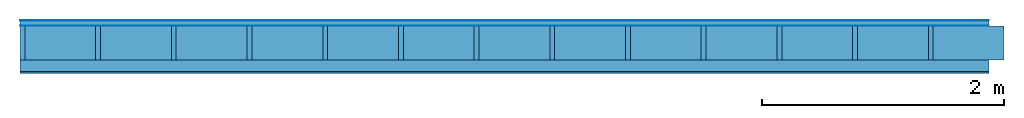
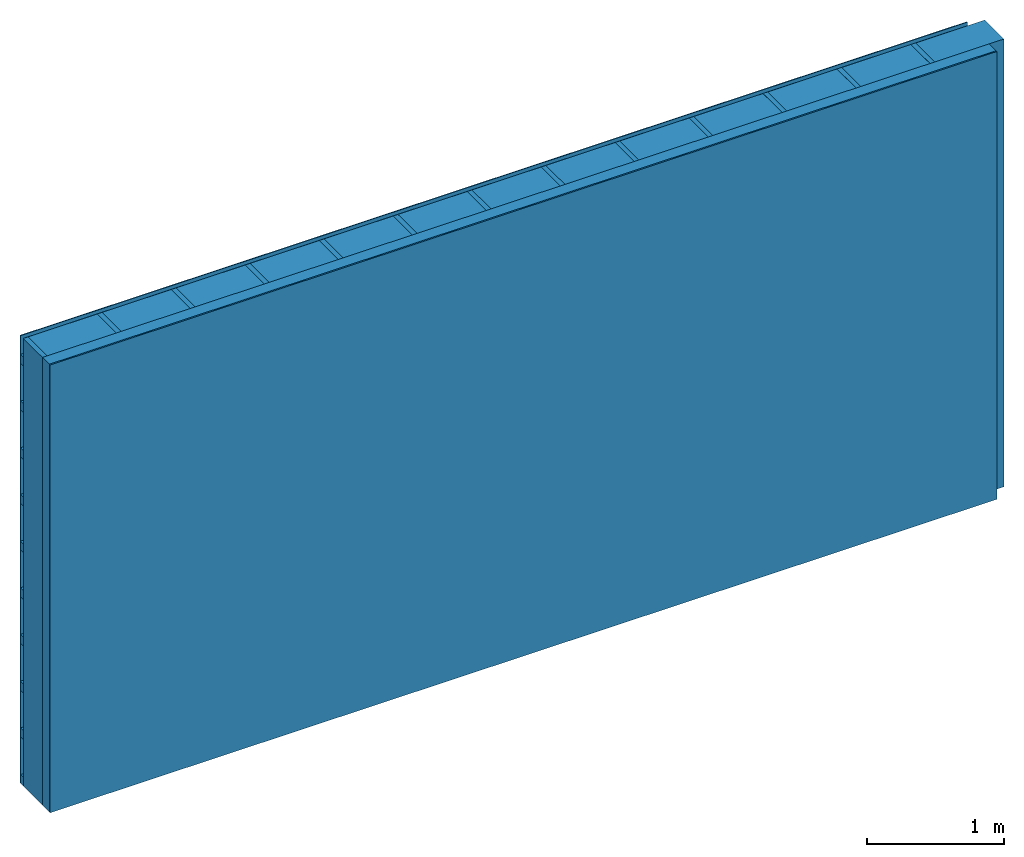
# One storey: 4 plates, 3 members, 1 element without a shape of its own.
"""IFC4 building model written with IfcOpenShell, lengths in metres."""

from ifc_helpers import new_model, si_unit, derived_unit, direction, frame, frame_2d, origin, origin_with_axes, place, context, project, spatial, rectangle, extrude, material, layer, layer_set, type_object, element, aggregate, save


model = new_model("IFC4")

# Units and contexts
plan_context = context("Plan", 3, precision=1e-05, world=origin(), true_north=direction((0.0, 1.0)))
model_context = context("Model", 3, precision=1e-05, world=origin(), true_north=direction((0.0, 1.0)))
ifc_project = project(units=[si_unit("LENGTHUNIT", "METRE"), derived_unit("SOUNDPRESSUREUNIT", [(si_unit("PRESSUREUNIT", "PASCAL", prefix="MICRO"), 0)]), si_unit("ENERGYUNIT", "JOULE", prefix="MEGA"), si_unit("MASSUNIT", "GRAM", prefix="KILO"), derived_unit("THERMALTRANSMITTANCEUNIT", [(si_unit("POWERUNIT", "WATT"), 1), (si_unit("AREAUNIT", "SQUARE_METRE"), -1), (si_unit("THERMODYNAMICTEMPERATUREUNIT", "KELVIN"), -1)]), derived_unit("AREADENSITYUNIT", [(si_unit("MASSUNIT", "GRAM", prefix="KILO"), 1), (si_unit("AREAUNIT", "SQUARE_METRE"), -1)]), derived_unit("USERDEFINED", [(si_unit("ENERGYUNIT", "JOULE", prefix="MEGA"), 1), (si_unit("AREAUNIT", "SQUARE_METRE"), -1)])], contexts=[plan_context, model_context])

# Site, building, storey
site = spatial("IfcSite", under=ifc_project)
building_placement = place(None, origin())
building = spatial("IfcBuilding", under=site, at=building_placement)
storey_placement = place(building_placement, origin())
storey = spatial("IfcBuildingStorey", under=building, at=storey_placement)

# Wall, members, plates
ifc_material_1 = material(Name="mineral, cement-based building board", Category="03.003")
ifc_layer_1 = layer(ifc_material_1, 0.008, Name="Cover 1st layer")
ifc_layer_2 = layer(None, 0.04, Name="Battens / profiles (ventilation)")
ifc_material_2 = material(Name="Vapor-permeable water barrier", Category="09.006")
ifc_layer_3 = layer(ifc_material_2, 0.0005, Name="outside 1st layer")
ifc_material_3 = material(Name="of the art")
ifc_layer_4 = layer(ifc_material_3, 0.0, Name="Bond")
ifc_layer_5 = layer(None, 0.28, Name="Support")
ifc_layer_6 = layer(ifc_material_3, 0.0, Name="Bond")
ifc_material_4 = material(Name="Solid timber panel")
ifc_layer_7 = layer(ifc_material_4, 0.1, Name="1st layer")
ifc_material_5 = material(Name="Plasterboard type A", Category="03.008")
ifc_layer_8 = layer(ifc_material_5, 0.0125, Name="Covering 1st layer")
ifc_material_6 = material(Name="joints", Category="04.017")
ifc_layer_9 = layer(ifc_material_6, 0.0, Name="Surface")
ifc_layer_set = layer_set([ifc_layer_1, ifc_layer_2, ifc_layer_3, ifc_layer_4, ifc_layer_5, ifc_layer_6, ifc_layer_7, ifc_layer_8, ifc_layer_9])
wall_type = type_object("IfcWallType", Name="D1002", PredefinedType="NOTDEFINED", material=ifc_layer_set)
wall_placement = place(None, frame((0.0, 0.0, 0.0), z_axis=(0.0, -1.0, 0.0), x_axis=(1.0, 0.0, 0.0)))
wall = element("IfcWall", 1, at=wall_placement, inside=storey, type_object=wall_type, material=ifc_layer_set, Name="Wall #1")
ifc_material_7 = material()
member_1_placement = place(wall_placement, origin())
member_1 = element("IfcMember", 2, at=member_1_placement, material=ifc_material_7, Name="Battens / profiles (ventilation)", context=plan_context, shape_type="SweptSolid", body=[
    extrude(rectangle(XDim=0.08, YDim=0.04, at=frame_2d((0.04, 0.02), x_axis=(1.0, 0.0))), frame((0.0, 0.0, 0.008), z_axis=(1.0, 0.0, 0.0), x_axis=(0.0, 1.0, 0.0)), (0.0, 0.0, 1.0), 8.0),
    extrude(rectangle(XDim=0.08, YDim=0.04, at=frame_2d((0.04, 0.02), x_axis=(1.0, 0.0))), frame((0.0, 0.417, 0.008), z_axis=(1.0, 0.0, 0.0), x_axis=(0.0, 1.0, 0.0)), (0.0, 0.0, 1.0), 8.0),
    extrude(rectangle(XDim=0.08, YDim=0.04, at=frame_2d((0.04, 0.02), x_axis=(1.0, 0.0))), frame((0.0, 0.834, 0.008), z_axis=(1.0, 0.0, 0.0), x_axis=(0.0, 1.0, 0.0)), (0.0, 0.0, 1.0), 8.0),
    extrude(rectangle(XDim=0.08, YDim=0.04, at=frame_2d((0.04, 0.02), x_axis=(1.0, 0.0))), frame((0.0, 1.251, 0.008), z_axis=(1.0, 0.0, 0.0), x_axis=(0.0, 1.0, 0.0)), (0.0, 0.0, 1.0), 8.0),
    extrude(rectangle(XDim=0.08, YDim=0.04, at=frame_2d((0.04, 0.02), x_axis=(1.0, 0.0))), frame((0.0, 1.668, 0.008), z_axis=(1.0, 0.0, 0.0), x_axis=(0.0, 1.0, 0.0)), (0.0, 0.0, 1.0), 8.0),
    extrude(rectangle(XDim=0.08, YDim=0.04, at=frame_2d((0.04, 0.02), x_axis=(1.0, 0.0))), frame((0.0, 2.085, 0.008), z_axis=(1.0, 0.0, 0.0), x_axis=(0.0, 1.0, 0.0)), (0.0, 0.0, 1.0), 8.0),
    extrude(rectangle(XDim=0.08, YDim=0.04, at=frame_2d((0.04, 0.02), x_axis=(1.0, 0.0))), frame((0.0, 2.502, 0.008), z_axis=(1.0, 0.0, 0.0), x_axis=(0.0, 1.0, 0.0)), (0.0, 0.0, 1.0), 8.0),
    extrude(rectangle(XDim=0.08, YDim=0.04, at=frame_2d((0.04, 0.02), x_axis=(1.0, 0.0))), frame((0.0, 2.919, 0.008), z_axis=(1.0, 0.0, 0.0), x_axis=(0.0, 1.0, 0.0)), (0.0, 0.0, 1.0), 8.0),
    extrude(rectangle(XDim=0.08, YDim=0.04, at=frame_2d((0.04, 0.02), x_axis=(1.0, 0.0))), frame((0.0, 3.336, 0.008), z_axis=(1.0, 0.0, 0.0), x_axis=(0.0, 1.0, 0.0)), (0.0, 0.0, 1.0), 8.0),
    extrude(rectangle(XDim=0.08, YDim=0.04, at=frame_2d((0.04, 0.02), x_axis=(1.0, 0.0))), frame((0.0, 3.753, 0.008), z_axis=(1.0, 0.0, 0.0), x_axis=(0.0, 1.0, 0.0)), (0.0, 0.0, 1.0), 8.0),
])
ifc_material_8 = material()
member_2_placement = place(wall_placement, origin())
member_2 = element("IfcMember", 3, at=member_2_placement, material=ifc_material_8, Name="Support", context=plan_context, shape_type="SweptSolid", body=[
    extrude(rectangle(XDim=0.04, YDim=0.28, at=frame_2d((0.02, 0.14), x_axis=(1.0, 0.0))), frame((0.0, 4.0, 0.0485), z_axis=(0.0, -1.0, 0.0), x_axis=(1.0, 0.0, 0.0)), (0.0, 0.0, 1.0), 4.0),
    extrude(rectangle(XDim=0.04, YDim=0.28, at=frame_2d((0.02, 0.14), x_axis=(1.0, 0.0))), frame((0.625, 4.0, 0.0485), z_axis=(0.0, -1.0, 0.0), x_axis=(1.0, 0.0, 0.0)), (0.0, 0.0, 1.0), 4.0),
    extrude(rectangle(XDim=0.04, YDim=0.28, at=frame_2d((0.02, 0.14), x_axis=(1.0, 0.0))), frame((1.25, 4.0, 0.0485), z_axis=(0.0, -1.0, 0.0), x_axis=(1.0, 0.0, 0.0)), (0.0, 0.0, 1.0), 4.0),
    extrude(rectangle(XDim=0.04, YDim=0.28, at=frame_2d((0.02, 0.14), x_axis=(1.0, 0.0))), frame((1.875, 4.0, 0.0485), z_axis=(0.0, -1.0, 0.0), x_axis=(1.0, 0.0, 0.0)), (0.0, 0.0, 1.0), 4.0),
    extrude(rectangle(XDim=0.04, YDim=0.28, at=frame_2d((0.02, 0.14), x_axis=(1.0, 0.0))), frame((2.5, 4.0, 0.0485), z_axis=(0.0, -1.0, 0.0), x_axis=(1.0, 0.0, 0.0)), (0.0, 0.0, 1.0), 4.0),
    extrude(rectangle(XDim=0.04, YDim=0.28, at=frame_2d((0.02, 0.14), x_axis=(1.0, 0.0))), frame((3.125, 4.0, 0.0485), z_axis=(0.0, -1.0, 0.0), x_axis=(1.0, 0.0, 0.0)), (0.0, 0.0, 1.0), 4.0),
    extrude(rectangle(XDim=0.04, YDim=0.28, at=frame_2d((0.02, 0.14), x_axis=(1.0, 0.0))), frame((3.75, 4.0, 0.0485), z_axis=(0.0, -1.0, 0.0), x_axis=(1.0, 0.0, 0.0)), (0.0, 0.0, 1.0), 4.0),
    extrude(rectangle(XDim=0.04, YDim=0.28, at=frame_2d((0.02, 0.14), x_axis=(1.0, 0.0))), frame((4.375, 4.0, 0.0485), z_axis=(0.0, -1.0, 0.0), x_axis=(1.0, 0.0, 0.0)), (0.0, 0.0, 1.0), 4.0),
    extrude(rectangle(XDim=0.04, YDim=0.28, at=frame_2d((0.02, 0.14), x_axis=(1.0, 0.0))), frame((5.0, 4.0, 0.0485), z_axis=(0.0, -1.0, 0.0), x_axis=(1.0, 0.0, 0.0)), (0.0, 0.0, 1.0), 4.0),
    extrude(rectangle(XDim=0.04, YDim=0.28, at=frame_2d((0.02, 0.14), x_axis=(1.0, 0.0))), frame((5.625, 4.0, 0.0485), z_axis=(0.0, -1.0, 0.0), x_axis=(1.0, 0.0, 0.0)), (0.0, 0.0, 1.0), 4.0),
    extrude(rectangle(XDim=0.04, YDim=0.28, at=frame_2d((0.02, 0.14), x_axis=(1.0, 0.0))), frame((6.25, 4.0, 0.0485), z_axis=(0.0, -1.0, 0.0), x_axis=(1.0, 0.0, 0.0)), (0.0, 0.0, 1.0), 4.0),
    extrude(rectangle(XDim=0.04, YDim=0.28, at=frame_2d((0.02, 0.14), x_axis=(1.0, 0.0))), frame((6.875, 4.0, 0.0485), z_axis=(0.0, -1.0, 0.0), x_axis=(1.0, 0.0, 0.0)), (0.0, 0.0, 1.0), 4.0),
    extrude(rectangle(XDim=0.04, YDim=0.28, at=frame_2d((0.02, 0.14), x_axis=(1.0, 0.0))), frame((7.5, 4.0, 0.0485), z_axis=(0.0, -1.0, 0.0), x_axis=(1.0, 0.0, 0.0)), (0.0, 0.0, 1.0), 4.0),
])
ifc_material_9 = material(Name="Mineral wool")
member_3_placement = place(wall_placement, origin())
member_3 = element("IfcMember", 4, at=member_3_placement, material=ifc_material_9, Name="Cavity", context=plan_context, shape_type="SweptSolid", body=[
    extrude(rectangle(XDim=0.585, YDim=0.28, at=frame_2d((0.2925, 0.14), x_axis=(1.0, 0.0))), frame((0.04, 4.0, 0.0485), z_axis=(0.0, -1.0, 0.0), x_axis=(1.0, 0.0, 0.0)), (0.0, 0.0, 1.0), 4.0),
    extrude(rectangle(XDim=0.585, YDim=0.28, at=frame_2d((0.2925, 0.14), x_axis=(1.0, 0.0))), frame((0.665, 4.0, 0.0485), z_axis=(0.0, -1.0, 0.0), x_axis=(1.0, 0.0, 0.0)), (0.0, 0.0, 1.0), 4.0),
    extrude(rectangle(XDim=0.585, YDim=0.28, at=frame_2d((0.2925, 0.14), x_axis=(1.0, 0.0))), frame((1.29, 4.0, 0.0485), z_axis=(0.0, -1.0, 0.0), x_axis=(1.0, 0.0, 0.0)), (0.0, 0.0, 1.0), 4.0),
    extrude(rectangle(XDim=0.585, YDim=0.28, at=frame_2d((0.2925, 0.14), x_axis=(1.0, 0.0))), frame((1.915, 4.0, 0.0485), z_axis=(0.0, -1.0, 0.0), x_axis=(1.0, 0.0, 0.0)), (0.0, 0.0, 1.0), 4.0),
    extrude(rectangle(XDim=0.585, YDim=0.28, at=frame_2d((0.2925, 0.14), x_axis=(1.0, 0.0))), frame((2.54, 4.0, 0.0485), z_axis=(0.0, -1.0, 0.0), x_axis=(1.0, 0.0, 0.0)), (0.0, 0.0, 1.0), 4.0),
    extrude(rectangle(XDim=0.585, YDim=0.28, at=frame_2d((0.2925, 0.14), x_axis=(1.0, 0.0))), frame((3.165, 4.0, 0.0485), z_axis=(0.0, -1.0, 0.0), x_axis=(1.0, 0.0, 0.0)), (0.0, 0.0, 1.0), 4.0),
    extrude(rectangle(XDim=0.585, YDim=0.28, at=frame_2d((0.2925, 0.14), x_axis=(1.0, 0.0))), frame((3.79, 4.0, 0.0485), z_axis=(0.0, -1.0, 0.0), x_axis=(1.0, 0.0, 0.0)), (0.0, 0.0, 1.0), 4.0),
    extrude(rectangle(XDim=0.585, YDim=0.28, at=frame_2d((0.2925, 0.14), x_axis=(1.0, 0.0))), frame((4.415, 4.0, 0.0485), z_axis=(0.0, -1.0, 0.0), x_axis=(1.0, 0.0, 0.0)), (0.0, 0.0, 1.0), 4.0),
    extrude(rectangle(XDim=0.585, YDim=0.28, at=frame_2d((0.2925, 0.14), x_axis=(1.0, 0.0))), frame((5.04, 4.0, 0.0485), z_axis=(0.0, -1.0, 0.0), x_axis=(1.0, 0.0, 0.0)), (0.0, 0.0, 1.0), 4.0),
    extrude(rectangle(XDim=0.585, YDim=0.28, at=frame_2d((0.2925, 0.14), x_axis=(1.0, 0.0))), frame((5.665, 4.0, 0.0485), z_axis=(0.0, -1.0, 0.0), x_axis=(1.0, 0.0, 0.0)), (0.0, 0.0, 1.0), 4.0),
    extrude(rectangle(XDim=0.585, YDim=0.28, at=frame_2d((0.2925, 0.14), x_axis=(1.0, 0.0))), frame((6.29, 4.0, 0.0485), z_axis=(0.0, -1.0, 0.0), x_axis=(1.0, 0.0, 0.0)), (0.0, 0.0, 1.0), 4.0),
    extrude(rectangle(XDim=0.585, YDim=0.28, at=frame_2d((0.2925, 0.14), x_axis=(1.0, 0.0))), frame((6.915, 4.0, 0.0485), z_axis=(0.0, -1.0, 0.0), x_axis=(1.0, 0.0, 0.0)), (0.0, 0.0, 1.0), 4.0),
    extrude(rectangle(XDim=0.585, YDim=0.28, at=frame_2d((0.2925, 0.14), x_axis=(1.0, 0.0))), frame((7.54, 4.0, 0.0485), z_axis=(0.0, -1.0, 0.0), x_axis=(1.0, 0.0, 0.0)), (0.0, 0.0, 1.0), 4.0),
])
plate_1_placement = place(wall_placement, origin())
plate_1 = element("IfcPlate", 5, at=plate_1_placement, material=ifc_material_1, Name="Cover 1st layer", context=plan_context, shape_type="SweptSolid", body=[
    extrude(rectangle(XDim=8.0, YDim=4.0, at=frame_2d((4.0, 2.0), x_axis=(1.0, 0.0))), origin_with_axes(), (0.0, 0.0, 1.0), 0.008),
])
plate_2_placement = place(wall_placement, origin())
plate_2 = element("IfcPlate", 6, at=plate_2_placement, material=ifc_material_2, Name="outside 1st layer", context=plan_context, shape_type="SweptSolid", body=[
    extrude(rectangle(XDim=8.0, YDim=4.0, at=frame_2d((4.0, 2.0), x_axis=(1.0, 0.0))), frame((0.0, 0.0, 0.048), z_axis=(0.0, 0.0, 1.0), x_axis=(1.0, 0.0, 0.0)), (0.0, 0.0, 1.0), 0.0005),
])
plate_3_placement = place(wall_placement, origin())
plate_3 = element("IfcPlate", 7, at=plate_3_placement, material=ifc_material_4, Name="1st layer", context=plan_context, shape_type="SweptSolid", body=[
    extrude(rectangle(XDim=8.0, YDim=4.0, at=frame_2d((4.0, 2.0), x_axis=(1.0, 0.0))), frame((0.0, 0.0, 0.3285), z_axis=(0.0, 0.0, 1.0), x_axis=(1.0, 0.0, 0.0)), (0.0, 0.0, 1.0), 0.1),
])
plate_4_placement = place(wall_placement, origin())
plate_4 = element("IfcPlate", 8, at=plate_4_placement, material=ifc_material_5, Name="Covering 1st layer", context=plan_context, shape_type="SweptSolid", body=[
    extrude(rectangle(XDim=8.0, YDim=4.0, at=frame_2d((4.0, 2.0), x_axis=(1.0, 0.0))), frame((0.0, 0.0, 0.4285), z_axis=(0.0, 0.0, 1.0), x_axis=(1.0, 0.0, 0.0)), (0.0, 0.0, 1.0), 0.0125),
])
aggregate(wall, [plate_1, member_1, plate_2, member_2, member_3, plate_3, plate_4])

save(model, "model.ifc")
